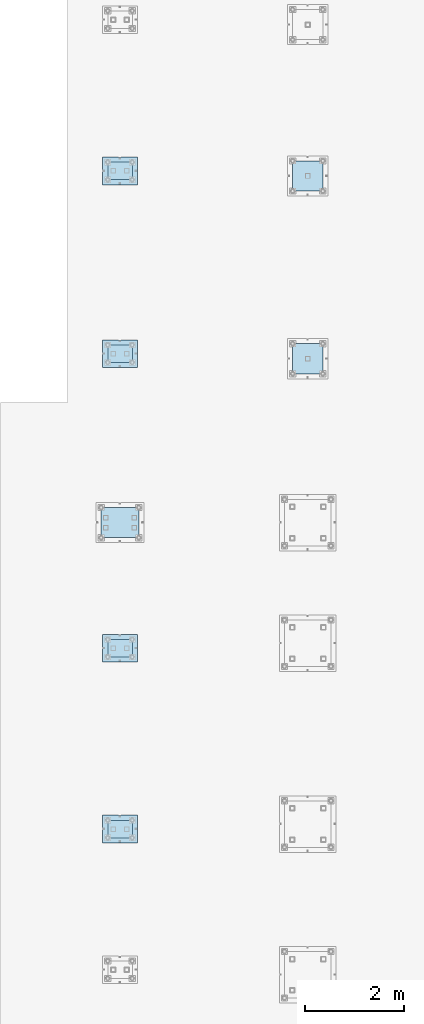
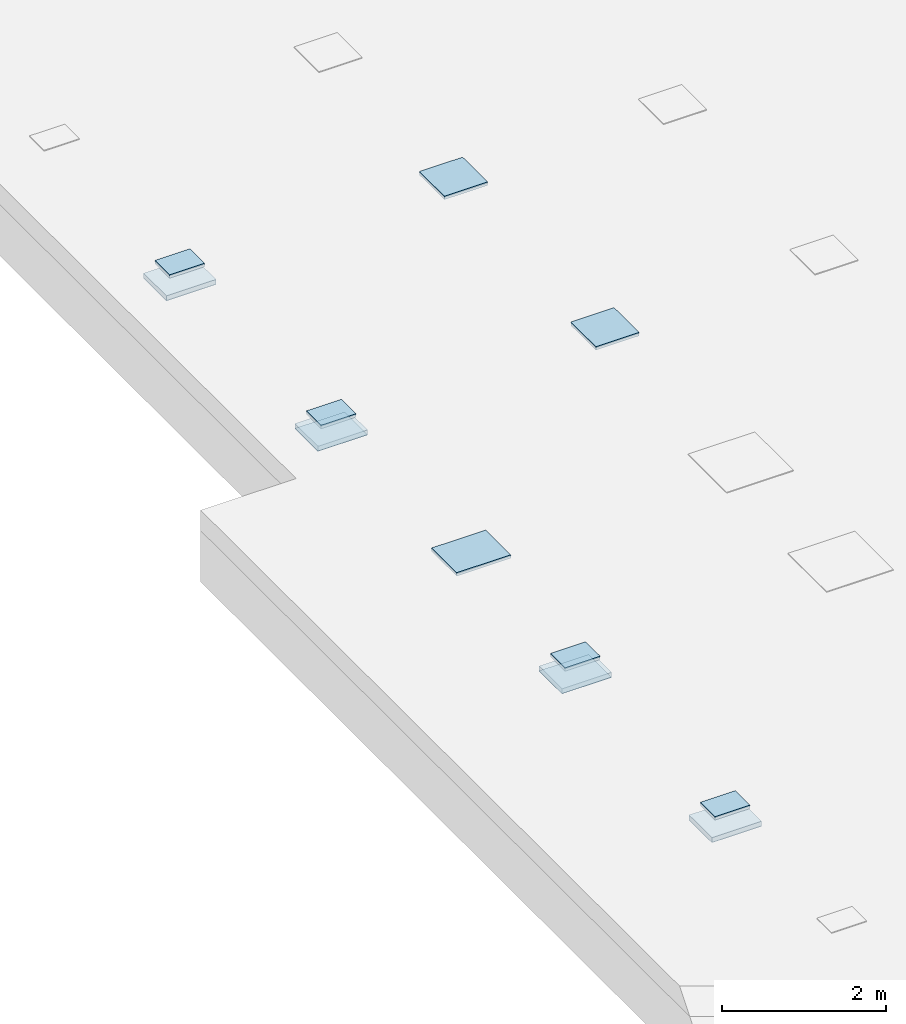
# One storey, part 3596 of 3843: 15 plates, 11 elements without a shape of their own.
"""IFC2X3 building model written with IfcOpenShell, lengths in millimetres."""

from ifc_helpers import new_model, si_unit, frame, origin_with_axes, place, context, subcontext, project, spatial, faceted_brep, material, type_object, element, aggregate, save


model = new_model("IFC2X3")

# Units and contexts
model_context = context("Model", 3, precision=1e-05, world=origin_with_axes())
body_context = subcontext(model_context, "Body", "Model", "MODEL_VIEW")
ifc_project = project(units=[si_unit("LENGTHUNIT", "METRE", prefix="MILLI"), si_unit("AREAUNIT", "SQUARE_METRE"), si_unit("VOLUMEUNIT", "CUBIC_METRE"), si_unit("MASSUNIT", "GRAM", prefix="KILO"), si_unit("TIMEUNIT", "SECOND"), si_unit("PLANEANGLEUNIT", "RADIAN"), si_unit("SOLIDANGLEUNIT", "STERADIAN"), si_unit("THERMODYNAMICTEMPERATUREUNIT", "DEGREE_CELSIUS"), si_unit("LUMINOUSINTENSITYUNIT", "LUMEN")], contexts=[model_context])

# Site, building, storey
site_placement = place(None, origin_with_axes())
site = spatial("IfcSite", under=ifc_project, at=site_placement, CompositionType="ELEMENT")
building_placement = place(site_placement, origin_with_axes())
building = spatial("IfcBuilding", under=site, at=building_placement, Name="Undefined", CompositionType="ELEMENT")
storey_placement = place(building_placement, origin_with_axes())
storey = spatial("IfcBuildingStorey", under=building, at=storey_placement, Name="Undefined", CompositionType="ELEMENT", Elevation=0.0)

# Assembly, plate
assembly_1_placement = place(storey_placement, origin_with_axes())
assembly_1 = element("IfcElementAssembly", 1, at=assembly_1_placement, inside=storey, Name="EMBED_PLATE", AssemblyPlace="NOTDEFINED", PredefinedType="RIGID_FRAME")
ifc_material = material(Name="STEEL/A572-50")
plate_type_1 = type_object("IfcPlateType", PredefinedType="NOTDEFINED")
plate_1_placement = place(assembly_1_placement, frame((104908.35, 32181.8, 30054.55), z_axis=(0.0, 1.0, 0.0), x_axis=(1.0, 0.0, 0.0)))
plate_1 = element("IfcPlate", 2, at=plate_1_placement, type_object=plate_type_1, material=ifc_material, Name="EMBED_PLATE", context=body_context, shape_type="Brep", body=[
    faceted_brep([(0.0, -25.3999996185303, 0.0), (0.0, -25.4000000000015, 355.599999999999), (0.0, 25.4000000000015, 355.599999999999), (0.0, 25.3999996185303, 0.0), (495.300000000003, -25.4000000000015, 355.599999999999), (495.300000000003, 25.4000000000015, 355.599999999999), (495.300000000003, -25.4000000000015, 0.0), (495.300000000003, 25.4000000000015, 0.0)], [[[0, 1, 2, 3]], [[1, 4, 5, 2]], [[4, 6, 7, 5]], [[6, 0, 3, 7]], [[5, 7, 3, 2]], [[6, 4, 1, 0]]]),
])

assembly_2_placement = place(storey_placement, origin_with_axes())
assembly_2 = element("IfcElementAssembly", 3, at=assembly_2_placement, inside=storey, Name="EMBED_PLATE", AssemblyPlace="NOTDEFINED", PredefinedType="RIGID_FRAME")
plate_2_placement = place(assembly_2_placement, frame((104908.35, 35839.4, 30054.55), z_axis=(0.0, 1.0, 0.0), x_axis=(1.0, 0.0, 0.0)))
plate_2 = element("IfcPlate", 4, at=plate_2_placement, type_object=plate_type_1, material=ifc_material, Name="EMBED_PLATE", context=body_context, shape_type="Brep", body=[
    faceted_brep([(0.0, -25.3999996185303, 0.0), (0.0, -25.4000000000015, 355.599999999999), (0.0, 25.4000000000015, 355.599999999999), (0.0, 25.3999996185303, 0.0), (495.300000000003, -25.4000000000015, 355.599999999999), (495.300000000003, 25.4000000000015, 355.599999999999), (495.300000000003, -25.4000000000015, 0.0), (495.300000000003, 25.4000000000015, 0.0)], [[[0, 1, 2, 3]], [[1, 4, 5, 2]], [[4, 6, 7, 5]], [[6, 0, 3, 7]], [[5, 7, 3, 2]], [[6, 4, 1, 0]]]),
])

assembly_3_placement = place(storey_placement, origin_with_axes())
assembly_3 = element("IfcElementAssembly", 5, at=assembly_3_placement, inside=storey, Name="EMBED_PLATE", AssemblyPlace="NOTDEFINED", PredefinedType="RIGID_FRAME")
plate_3_placement = place(assembly_3_placement, frame((104908.35, 41795.7, 30054.55), z_axis=(0.0, 1.0, 0.0), x_axis=(1.0, 0.0, 0.0)))
plate_3 = element("IfcPlate", 6, at=plate_3_placement, type_object=plate_type_1, material=ifc_material, Name="EMBED_PLATE", context=body_context, shape_type="Brep", body=[
    faceted_brep([(0.0, -25.3999996185303, 0.0), (0.0, -25.4000000000015, 355.599999999999), (0.0, 25.4000000000015, 355.599999999999), (0.0, 25.3999996185303, 0.0), (495.300000000003, -25.4000000000015, 355.599999999999), (495.300000000003, 25.4000000000015, 355.599999999999), (495.300000000003, -25.4000000000015, 0.0), (495.300000000003, 25.4000000000015, 0.0)], [[[0, 1, 2, 3]], [[1, 4, 5, 2]], [[4, 6, 7, 5]], [[6, 0, 3, 7]], [[5, 7, 3, 2]], [[6, 4, 1, 0]]]),
])

assembly_4_placement = place(storey_placement, origin_with_axes())
assembly_4 = element("IfcElementAssembly", 7, at=assembly_4_placement, inside=storey, Name="EMBED_PLATE", AssemblyPlace="NOTDEFINED", PredefinedType="RIGID_FRAME")
plate_4_placement = place(assembly_4_placement, frame((104908.35, 45491.4, 30054.55), z_axis=(0.0, 1.0, 0.0), x_axis=(1.0, 0.0, 0.0)))
plate_4 = element("IfcPlate", 8, at=plate_4_placement, type_object=plate_type_1, material=ifc_material, Name="EMBED_PLATE", context=body_context, shape_type="Brep", body=[
    faceted_brep([(0.0, -25.3999996185303, 0.0), (0.0, -25.4000000000015, 355.599999999999), (0.0, 25.4000000000015, 355.599999999999), (0.0, 25.3999996185303, 0.0), (495.300000000003, -25.4000000000015, 355.599999999999), (495.300000000003, 25.4000000000015, 355.599999999999), (495.300000000003, -25.4000000000015, 0.0), (495.300000000003, 25.4000000000015, 0.0)], [[[0, 1, 2, 3]], [[1, 4, 5, 2]], [[4, 6, 7, 5]], [[6, 0, 3, 7]], [[5, 7, 3, 2]], [[6, 4, 1, 0]]]),
])

assembly_5_placement = place(storey_placement, origin_with_axes())
assembly_5 = element("IfcElementAssembly", 9, at=assembly_5_placement, inside=storey, Name="TEMPLATE", AssemblyPlace="NOTDEFINED", PredefinedType="RIGID_FRAME")
plate_type_2 = type_object("IfcPlateType", PredefinedType="NOTDEFINED")
plate_5_placement = place(assembly_5_placement, frame((104806.75, 32080.2, 29791.025), z_axis=(0.0, 1.0, 0.0), x_axis=(1.0, 0.0, 0.0)))
plate_5 = element("IfcPlate", 10, at=plate_5_placement, type_object=plate_type_2, material=ifc_material, Name="TEMPLATE", context=body_context, shape_type="Brep", body=[
    faceted_brep([(0.0, -3.17499999999927, 0.0), (-1.45519152283669e-11, -3.17499999999927, 558.799999999945), (-1.45519152283669e-11, 3.17499999999927, 558.799999999945), (0.0, 3.17499999999927, 0.0), (698.5, -3.17499999999927, 558.799999999974), (698.5, 3.17499999999927, 558.799999999974), (698.5, -3.17499999999927, 0.0), (698.5, 3.17499999999927, 0.0)], [[[0, 1, 2, 3]], [[1, 4, 5, 2]], [[4, 6, 7, 5]], [[6, 0, 3, 7]], [[5, 7, 3, 2]], [[6, 4, 1, 0]]]),
])
aggregate(assembly_5, [plate_5])

assembly_6_placement = place(storey_placement, origin_with_axes())
assembly_6 = element("IfcElementAssembly", 11, at=assembly_6_placement, inside=storey, Name="TEMPLATE", AssemblyPlace="NOTDEFINED", PredefinedType="RIGID_FRAME")
plate_6_placement = place(assembly_6_placement, frame((104806.75, 35737.8, 29791.025), z_axis=(0.0, 1.0, 0.0), x_axis=(1.0, 0.0, 0.0)))
plate_6 = element("IfcPlate", 12, at=plate_6_placement, type_object=plate_type_2, material=ifc_material, Name="TEMPLATE", context=body_context, shape_type="Brep", body=[
    faceted_brep([(0.0, -3.17499999999927, 0.0), (-1.45519152283669e-11, -3.17499999999927, 558.799999999945), (-1.45519152283669e-11, 3.17499999999927, 558.799999999945), (0.0, 3.17499999999927, 0.0), (698.5, -3.17499999999927, 558.799999999974), (698.5, 3.17499999999927, 558.799999999974), (698.5, -3.17499999999927, 0.0), (698.5, 3.17499999999927, 0.0)], [[[0, 1, 2, 3]], [[1, 4, 5, 2]], [[4, 6, 7, 5]], [[6, 0, 3, 7]], [[5, 7, 3, 2]], [[6, 4, 1, 0]]]),
])
aggregate(assembly_6, [plate_6])

assembly_7_placement = place(storey_placement, origin_with_axes())
assembly_7 = element("IfcElementAssembly", 13, at=assembly_7_placement, inside=storey, Name="TEMPLATE", AssemblyPlace="NOTDEFINED", PredefinedType="RIGID_FRAME")
plate_7_placement = place(assembly_7_placement, frame((104806.75, 41694.1, 29791.025), z_axis=(0.0, 1.0, 0.0), x_axis=(1.0, 0.0, 0.0)))
plate_7 = element("IfcPlate", 14, at=plate_7_placement, type_object=plate_type_2, material=ifc_material, Name="TEMPLATE", context=body_context, shape_type="Brep", body=[
    faceted_brep([(0.0, -3.17499999999927, 0.0), (-1.45519152283669e-11, -3.17499999999927, 558.799999999945), (-1.45519152283669e-11, 3.17499999999927, 558.799999999945), (0.0, 3.17499999999927, 0.0), (698.5, -3.17499999999927, 558.799999999974), (698.5, 3.17499999999927, 558.799999999974), (698.5, -3.17499999999927, 0.0), (698.5, 3.17499999999927, 0.0)], [[[0, 1, 2, 3]], [[1, 4, 5, 2]], [[4, 6, 7, 5]], [[6, 0, 3, 7]], [[5, 7, 3, 2]], [[6, 4, 1, 0]]]),
])
aggregate(assembly_7, [plate_7])

assembly_8_placement = place(storey_placement, origin_with_axes())
assembly_8 = element("IfcElementAssembly", 15, at=assembly_8_placement, inside=storey, Name="TEMPLATE", AssemblyPlace="NOTDEFINED", PredefinedType="RIGID_FRAME")
plate_8_placement = place(assembly_8_placement, frame((104806.75, 45389.8, 29791.025), z_axis=(0.0, 1.0, 0.0), x_axis=(1.0, 0.0, 0.0)))
plate_8 = element("IfcPlate", 16, at=plate_8_placement, type_object=plate_type_2, material=ifc_material, Name="TEMPLATE", context=body_context, shape_type="Brep", body=[
    faceted_brep([(0.0, -3.17499999999927, 0.0), (-1.45519152283669e-11, -3.17499999999927, 558.799999999945), (-1.45519152283669e-11, 3.17499999999927, 558.799999999945), (0.0, 3.17499999999927, 0.0), (698.5, -3.17499999999927, 558.799999999974), (698.5, 3.17499999999927, 558.799999999974), (698.5, -3.17499999999927, 0.0), (698.5, 3.17499999999927, 0.0)], [[[0, 1, 2, 3]], [[1, 4, 5, 2]], [[4, 6, 7, 5]], [[6, 0, 3, 7]], [[5, 7, 3, 2]], [[6, 4, 1, 0]]]),
])
aggregate(assembly_8, [plate_8])

# Plate
plate_type_3 = type_object("IfcPlateType", PredefinedType="NOTDEFINED")
plate_9_placement = place(assembly_1_placement, frame((105505.25, 32080.2, 29825.95), z_axis=(-1.0, 0.0, 0.0), x_axis=(0.0, 1.0, 0.0)))
plate_9 = element("IfcPlate", 17, at=plate_9_placement, type_object=plate_type_3, material=ifc_material, Name="EMBED_PLATE", context=body_context, shape_type="Brep", body=[
    faceted_brep([(0.0, -38.0999999999985, 0.0), (0.0, -38.0999999999985, 698.499999999985), (0.0, 38.0999999999985, 698.499999999985), (0.0, 38.0999999999985, 0.0), (558.799999999996, -38.0999999999985, 698.499999999985), (558.799999999996, 38.0999999999985, 698.499999999985), (558.799999999996, -38.0999999999985, 0.0), (558.799999999996, 38.0999999999985, 0.0)], [[[0, 1, 2, 3]], [[1, 4, 5, 2]], [[4, 6, 7, 5]], [[6, 0, 3, 7]], [[5, 7, 3, 2]], [[6, 4, 1, 0]]]),
])

aggregate(assembly_1, [plate_1, plate_9])

plate_10_placement = place(assembly_2_placement, frame((105505.25, 35737.8, 29825.95), z_axis=(-1.0, 0.0, 0.0), x_axis=(0.0, 1.0, 0.0)))
plate_10 = element("IfcPlate", 18, at=plate_10_placement, type_object=plate_type_3, material=ifc_material, Name="EMBED_PLATE", context=body_context, shape_type="Brep", body=[
    faceted_brep([(0.0, -38.0999999999985, 0.0), (0.0, -38.0999999999985, 698.499999999985), (0.0, 38.0999999999985, 698.499999999985), (0.0, 38.0999999999985, 0.0), (558.799999999996, -38.0999999999985, 698.499999999985), (558.799999999996, 38.0999999999985, 698.499999999985), (558.799999999996, -38.0999999999985, 0.0), (558.799999999996, 38.0999999999985, 0.0)], [[[0, 1, 2, 3]], [[1, 4, 5, 2]], [[4, 6, 7, 5]], [[6, 0, 3, 7]], [[5, 7, 3, 2]], [[6, 4, 1, 0]]]),
])

aggregate(assembly_2, [plate_2, plate_10])

plate_11_placement = place(assembly_3_placement, frame((105505.25, 41694.1, 29825.95), z_axis=(-1.0, 0.0, 0.0), x_axis=(0.0, 1.0, 0.0)))
plate_11 = element("IfcPlate", 19, at=plate_11_placement, type_object=plate_type_3, material=ifc_material, Name="EMBED_PLATE", context=body_context, shape_type="Brep", body=[
    faceted_brep([(0.0, -38.0999999999985, 0.0), (0.0, -38.0999999999985, 698.499999999985), (0.0, 38.0999999999985, 698.499999999985), (0.0, 38.0999999999985, 0.0), (558.799999999996, -38.0999999999985, 698.499999999985), (558.799999999996, 38.0999999999985, 698.499999999985), (558.799999999996, -38.0999999999985, 0.0), (558.799999999996, 38.0999999999985, 0.0)], [[[0, 1, 2, 3]], [[1, 4, 5, 2]], [[4, 6, 7, 5]], [[6, 0, 3, 7]], [[5, 7, 3, 2]], [[6, 4, 1, 0]]]),
])

aggregate(assembly_3, [plate_3, plate_11])

plate_12_placement = place(assembly_4_placement, frame((105505.25, 45389.8, 29825.95), z_axis=(-1.0, 0.0, 0.0), x_axis=(0.0, 1.0, 0.0)))
plate_12 = element("IfcPlate", 20, at=plate_12_placement, type_object=plate_type_3, material=ifc_material, Name="EMBED_PLATE", context=body_context, shape_type="Brep", body=[
    faceted_brep([(0.0, -38.0999999999985, 0.0), (0.0, -38.0999999999985, 698.499999999985), (0.0, 38.0999999999985, 698.499999999985), (0.0, 38.0999999999985, 0.0), (558.799999999996, -38.0999999999985, 698.499999999985), (558.799999999996, 38.0999999999985, 698.499999999985), (558.799999999996, -38.0999999999985, 0.0), (558.799999999996, 38.0999999999985, 0.0)], [[[0, 1, 2, 3]], [[1, 4, 5, 2]], [[4, 6, 7, 5]], [[6, 0, 3, 7]], [[5, 7, 3, 2]], [[6, 4, 1, 0]]]),
])

aggregate(assembly_4, [plate_4, plate_12])

# Assembly, plate
assembly_9_placement = place(storey_placement, origin_with_axes())
assembly_9 = element("IfcElementAssembly", 21, at=assembly_9_placement, inside=storey, Name="EMBED_PLATE", AssemblyPlace="NOTDEFINED", PredefinedType="RIGID_FRAME")
plate_type_4 = type_object("IfcPlateType", PredefinedType="NOTDEFINED")
plate_13_placement = place(assembly_9_placement, frame((109258.1, 42176.7, 30054.55), z_axis=(0.0, -1.0, 0.0), x_axis=(-1.0, 0.0, 0.0)))
plate_13 = element("IfcPlate", 22, at=plate_13_placement, type_object=plate_type_4, material=ifc_material, Name="EMBED_PLATE", context=body_context, shape_type="Brep", body=[
    faceted_brep([(0.0, -25.3999996185303, 0.0), (0.0, -25.4000000000015, 609.600000000006), (0.0, 25.4000000000015, 609.600000000006), (0.0, 25.3999996185303, 0.0), (609.600000000006, -25.4000000000015, 609.599999999999), (609.600000000006, 25.4000000000015, 609.599999999999), (609.600000000006, -25.4000000000015, 0.0), (609.600000000006, 25.4000000000015, 0.0)], [[[0, 1, 2, 3]], [[1, 4, 5, 2]], [[4, 6, 7, 5]], [[6, 0, 3, 7]], [[5, 7, 3, 2]], [[6, 4, 1, 0]]]),
])
aggregate(assembly_9, [plate_13])

assembly_10_placement = place(storey_placement, origin_with_axes())
assembly_10 = element("IfcElementAssembly", 23, at=assembly_10_placement, inside=storey, Name="EMBED_PLATE", AssemblyPlace="NOTDEFINED", PredefinedType="RIGID_FRAME")
plate_14_placement = place(assembly_10_placement, frame((109258.1, 45872.4, 30054.55), z_axis=(0.0, -1.0, 0.0), x_axis=(-1.0, 0.0, 0.0)))
plate_14 = element("IfcPlate", 24, at=plate_14_placement, type_object=plate_type_4, material=ifc_material, Name="EMBED_PLATE", context=body_context, shape_type="Brep", body=[
    faceted_brep([(0.0, -25.3999996185303, 0.0), (0.0, -25.4000000000015, 609.600000000006), (0.0, 25.4000000000015, 609.600000000006), (0.0, 25.3999996185303, 0.0), (609.600000000006, -25.4000000000015, 609.599999999999), (609.600000000006, 25.4000000000015, 609.599999999999), (609.600000000006, -25.4000000000015, 0.0), (609.600000000006, 25.4000000000015, 0.0)], [[[0, 1, 2, 3]], [[1, 4, 5, 2]], [[4, 6, 7, 5]], [[6, 0, 3, 7]], [[5, 7, 3, 2]], [[6, 4, 1, 0]]]),
])
aggregate(assembly_10, [plate_14])

assembly_11_placement = place(storey_placement, origin_with_axes())
assembly_11 = element("IfcElementAssembly", 25, at=assembly_11_placement, inside=storey, Name="EMBED_PLATE", AssemblyPlace="NOTDEFINED", PredefinedType="RIGID_FRAME")
plate_15_placement = place(assembly_11_placement, frame((105537.0, 38862.0, 30054.55), z_axis=(0.0, -1.0, 0.0), x_axis=(-1.0, 0.0, 0.0)))
plate_15 = element("IfcPlate", 26, at=plate_15_placement, type_object=plate_type_4, material=ifc_material, Name="EMBED_PLATE", context=body_context, shape_type="Brep", body=[
    faceted_brep([(0.0, -25.3999996185303, 0.0), (0.0, -25.4000000000015, 609.600000000006), (0.0, 25.4000000000015, 609.600000000006), (0.0, 25.3999996185303, 0.0), (762.0, -25.4000000000015, 609.600000000006), (762.0, 25.4000000000015, 609.600000000006), (762.0, -25.4000000000015, 0.0), (762.0, 25.4000000000015, 0.0)], [[[0, 1, 2, 3]], [[1, 4, 5, 2]], [[4, 6, 7, 5]], [[6, 0, 3, 7]], [[5, 7, 3, 2]], [[6, 4, 1, 0]]]),
])
aggregate(assembly_11, [plate_15])

save(model, "model.ifc")
